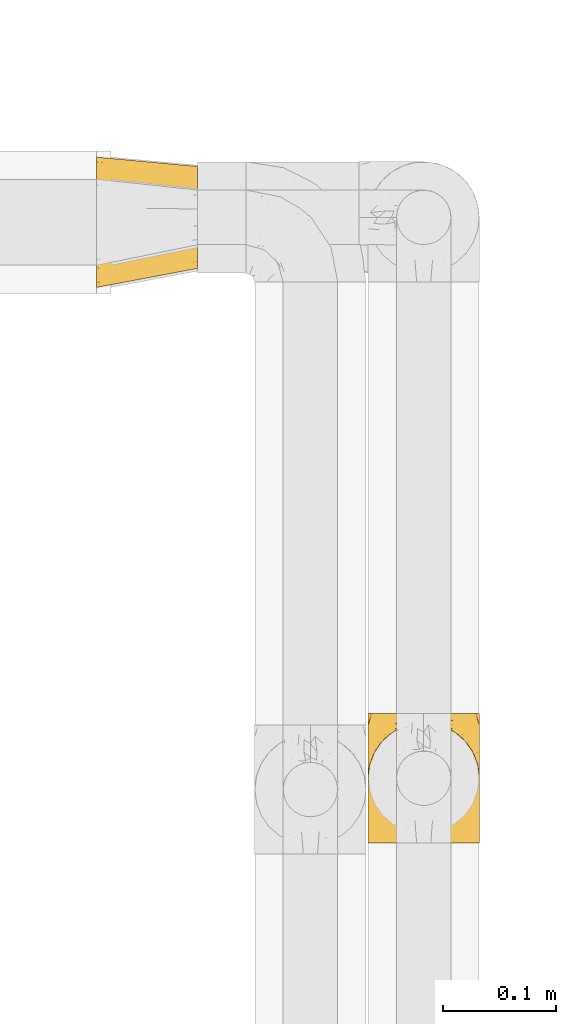
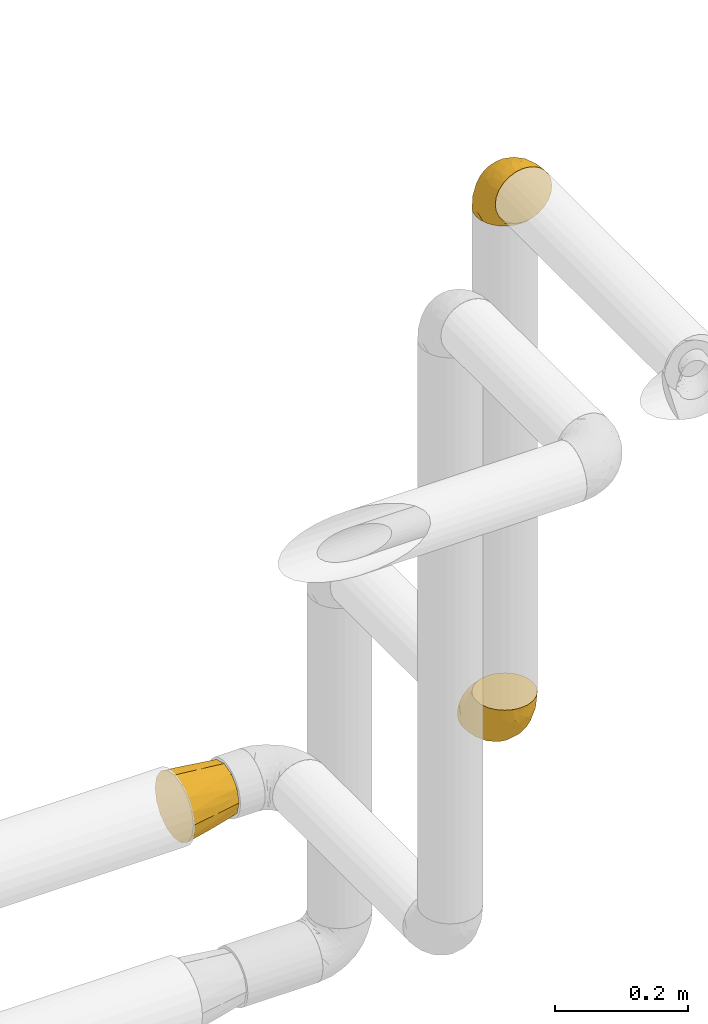
# One storey, part 416 of 827: 3 coverings.
"""IFC2X3 building model written with IfcOpenShell, lengths in millimetres."""

import ifcopenshell
import ifcopenshell.guid

model = None  # the IFC model being written
_history = None  # IfcOwnerHistory: only IFC2X3 demands one
_inside = {}  # id of a spatial element -> (the spatial element, [elements in it])
_under = {}  # id of a project, library or spatial element -> (it, [spatial elements below it])
_declared = {}  # id of a project -> (the project, [libraries it declares])
_typed = {}  # id of a type object -> (the type object, [elements of that type])
_made_of = {}  # id of a material, layer set ... -> (it, [elements and type objects made of it])


def new_model(schema):
    """Start an empty IFC model of exactly this schema.

    Asked for "IFC4X3", IfcOpenShell would pick the latest addendum, in which some entities
    have other attributes; the version numbers below select the first issue.
    IFC2X3 requires an IfcOwnerHistory on every rooted entity: one is made here for all.
    """
    global model, _history
    if schema == "IFC4X3":
        model = ifcopenshell.file(schema_version=(4, 3, 0, 0))
    else:
        model = ifcopenshell.file(schema=schema)
    _inside.clear()
    _under.clear()
    _declared.clear()
    _typed.clear()
    _made_of.clear()
    _history = None
    if model.schema == "IFC2X3":
        org = make("IfcOrganization", Name="unknown")
        user = make(
            "IfcPersonAndOrganization",
            ThePerson=make("IfcPerson", FamilyName="unknown"),
            TheOrganization=org,
        )
        app = make(
            "IfcApplication",
            ApplicationDeveloper=org,
            Version="unknown",
            ApplicationFullName="unknown",
            ApplicationIdentifier="unknown",
        )
        _history = make(
            "IfcOwnerHistory",
            OwningUser=user,
            OwningApplication=app,
            ChangeAction="ADDED",
            CreationDate=0,
        )
    return model


def make(cls, **values):
    """One entity of the class cls with the attributes given. An attribute that is None is left unset."""
    return model.create_entity(
        cls, **{name: value for name, value in values.items() if value is not None}
    )


def entity(cls, *values):
    """Any entity or typed value of the class cls, its attributes in the order of the schema. None: left unset."""
    e = model.create_entity(cls)
    for i, value in enumerate(values):
        if value is not None:
            e[i] = value
    return e


def rooted(cls, **values):
    """An entity with a GlobalId (a new one), such as an element, a storey or a relation."""
    return make(cls, GlobalId=ifcopenshell.guid.new(), OwnerHistory=_history, **values)


def si_unit(unit_type, name, prefix=None):
    """IfcSIUnit, for example si_unit("LENGTHUNIT", "METRE", prefix="MILLI")."""
    return make("IfcSIUnit", UnitType=unit_type, Prefix=prefix, Name=name)


def converted_unit(unit_type, name, factor, base, dimensions=None, offset=None):
    """IfcConversionBasedUnit, such as the inch: factor (a typed value) times the base unit."""
    return make(
        "IfcConversionBasedUnit"
        if offset is None
        else "IfcConversionBasedUnitWithOffset",
        ConversionOffset=offset,
        Dimensions=None
        if dimensions is None
        else entity("IfcDimensionalExponents", *dimensions),
        UnitType=unit_type,
        Name=name,
        ConversionFactor=make(
            "IfcMeasureWithUnit", ValueComponent=factor, UnitComponent=base
        ),
    )


def derived_unit(unit_type, elements):
    """IfcDerivedUnit: a product of units, each with its exponent."""
    return make(
        "IfcDerivedUnit",
        Elements=[
            make("IfcDerivedUnitElement", Unit=unit, Exponent=power)
            for unit, power in elements
        ],
        UnitType=unit_type,
    )


def assignment(units):
    """IfcUnitAssignment: the units of a project."""
    return None if units is None else make("IfcUnitAssignment", Units=units)


def point(xyz):
    """IfcCartesianPoint."""
    return None if xyz is None else make("IfcCartesianPoint", Coordinates=xyz)


def direction(xyz):
    """IfcDirection."""
    return None if xyz is None else make("IfcDirection", DirectionRatios=xyz)


def frame(location, z_axis=None, x_axis=None):
    """IfcAxis2Placement3D, a coordinate frame: its origin and axes. An axis left out is left unset."""
    return make(
        "IfcAxis2Placement3D",
        Location=point(location),
        Axis=direction(z_axis),
        RefDirection=direction(x_axis),
    )


def origin():
    """The frame at (0, 0, 0) with its axes left unset."""
    return frame((0.0, 0.0, 0.0))


def place(relative_to, where):
    """IfcLocalPlacement: puts the frame where relative to a parent placement (None: the world)."""
    return make(
        "IfcLocalPlacement", PlacementRelTo=relative_to, RelativePlacement=where
    )


def context(
    kind, dimensions, precision=None, world=None, true_north=None, identifier=None
):
    """IfcGeometricRepresentationContext, for example the 3D "Model" context."""
    return make(
        "IfcGeometricRepresentationContext",
        ContextIdentifier=identifier,
        ContextType=kind,
        CoordinateSpaceDimension=dimensions,
        Precision=precision,
        WorldCoordinateSystem=world,
        TrueNorth=true_north,
    )


def subcontext(parent, identifier, kind, view, scale=None):
    """IfcGeometricRepresentationSubContext, for example "Body" below "Model"."""
    return make(
        "IfcGeometricRepresentationSubContext",
        ContextIdentifier=identifier,
        ContextType=kind,
        ParentContext=parent,
        TargetScale=scale,
        TargetView=view,
    )


def project(units=None, contexts=None):
    """IfcProject with its units and contexts."""
    return rooted(
        "IfcProject",
        Name="project",
        RepresentationContexts=contexts,
        UnitsInContext=assignment(units),
    )


def spatial(cls, under=None, at=None, **own):
    """A site, building, storey or space (cls), placed at a placement, below another one or the project."""
    s = rooted(cls, ObjectPlacement=at, **own)
    if under is not None:
        _under.setdefault(under.id(), (under, []))[1].append(s)
    return s


def faces_of(points, faces, orient=None, outer=None):
    """IfcFace entities. A face is a list of loops; a loop is a list of indices into points, from 0.

    orient and outer hold one flag for each loop. By default every Orientation is true, the
    first loop of a face is its IfcFaceOuterBound and the others are IfcFaceBound.
    """
    made = []
    for i, loops in enumerate(faces):
        bounds = []
        for j, loop in enumerate(loops):
            is_outer = j == 0 if outer is None else outer[i][j]
            bounds.append(
                make(
                    "IfcFaceOuterBound" if is_outer else "IfcFaceBound",
                    Bound=make("IfcPolyLoop", Polygon=[points[k] for k in loop]),
                    Orientation=True if orient is None else orient[i][j],
                )
            )
        made.append(make("IfcFace", Bounds=bounds))
    return made


def faceted_brep(points, faces, orient=None, outer=None, voids=None):
    """IfcFacetedBrep: a solid bounded by flat faces; with voids (closed shells), ...WithVoids."""
    shared = [point(p) for p in points]
    hull = make("IfcClosedShell", CfsFaces=faces_of(shared, faces, orient, outer))
    if voids is None:
        return make("IfcFacetedBrep", Outer=hull)
    return make(
        "IfcFacetedBrepWithVoids",
        Outer=hull,
        Voids=[
            make(cls, CfsFaces=faces_of(shared, fs, o, b)) for cls, fs, o, b in voids
        ],
    )


def shape(context_of_items, identifier, shape_type, items):
    """IfcShapeRepresentation: the items that make up one representation, for example the "Body"."""
    return make(
        "IfcShapeRepresentation",
        ContextOfItems=context_of_items,
        RepresentationIdentifier=identifier,
        RepresentationType=shape_type,
        Items=items,
    )


def made_of(thing, what):
    """Note that an element or type object is made of a material, layer set ...; save() writes the relation."""
    if what is not None:
        _made_of.setdefault(what.id(), (what, []))[1].append(thing)
    return thing


def element(
    cls,
    number,
    at=None,
    inside=None,
    cuts=None,
    type_object=None,
    material=None,
    context=None,
    identifier="Body",
    shape_type=None,
    held_by="IfcProductDefinitionShape",
    body=None,
    shapes=None,
    **own,
):
    """One element of the class cls, such as IfcWall. Its Tag is "e" and its number.

    at: its placement. inside: the storey or other place that contains it. cuts: it is an
    opening in that element (IfcRelVoidsElement). A single representation is given by context,
    identifier, shape_type and body (its items); several are given by shapes. held_by: the class
    of the entity that holds the representations. save() writes the other relations.
    """
    e = rooted(cls, Tag="e%d" % number, ObjectPlacement=at, **own)
    if body is not None:
        shapes = [shape(context, identifier, shape_type, body)]
    if shapes is not None:
        e.Representation = make(held_by, Representations=shapes)
    if inside is not None:
        _inside.setdefault(inside.id(), (inside, []))[1].append(e)
    if cuts is not None:
        rooted(
            "IfcRelVoidsElement", RelatingBuildingElement=cuts, RelatedOpeningElement=e
        )
    if type_object is not None:
        _typed.setdefault(type_object.id(), (type_object, []))[1].append(e)
    return made_of(e, material)


def aggregate(whole, parts):
    """IfcRelAggregates: a whole, such as a stair, and the parts it consists of."""
    return rooted("IfcRelAggregates", RelatingObject=whole, RelatedObjects=parts)


def save(model, path):
    """Write the relations noted so far, then the file.

    IfcRelAggregates (storeys below a building ...), IfcRelContainedInSpatialStructure (elements
    in a storey), IfcRelDefinesByType, IfcRelAssociatesMaterial and IfcRelDeclares: one each for
    every whole, place, type object, material and project.
    """
    for whole, parts in _under.values():
        aggregate(whole, parts)
    for where, things in _inside.values():
        rooted(
            "IfcRelContainedInSpatialStructure",
            RelatedElements=things,
            RelatingStructure=where,
        )
    for kind, things in _typed.values():
        rooted("IfcRelDefinesByType", RelatedObjects=things, RelatingType=kind)
    for what, things in _made_of.values():
        rooted("IfcRelAssociatesMaterial", RelatedObjects=things, RelatingMaterial=what)
    for by, libraries in _declared.values():
        rooted("IfcRelDeclares", RelatingContext=by, RelatedDefinitions=libraries)
    model.write(path)


model = new_model("IFC2X3")

# Units and contexts
model_context = context("Model", 3, precision=0.01, world=origin(), true_north=direction((6.12303176911189e-17, 1.0)))
body_context = subcontext(model_context, "Body", "Model", "MODEL_VIEW")
ifc_project = project(units=[si_unit("LENGTHUNIT", "METRE", prefix="MILLI"), si_unit("AREAUNIT", "SQUARE_METRE"), si_unit("VOLUMEUNIT", "CUBIC_METRE"), converted_unit("PLANEANGLEUNIT", "DEGREE", entity("IfcRatioMeasure", 0.0174532925199433), si_unit("PLANEANGLEUNIT", "RADIAN"), dimensions=[0, 0, 0, 0, 0, 0, 0]), si_unit("MASSUNIT", "GRAM", prefix="KILO"), derived_unit("MASSDENSITYUNIT", [(si_unit("MASSUNIT", "GRAM", prefix="KILO"), 1), (si_unit("LENGTHUNIT", "METRE"), -3)]), derived_unit("MOMENTOFINERTIAUNIT", [(si_unit("LENGTHUNIT", "METRE"), 4)]), si_unit("TIMEUNIT", "SECOND"), si_unit("FREQUENCYUNIT", "HERTZ"), si_unit("THERMODYNAMICTEMPERATUREUNIT", "DEGREE_CELSIUS"), derived_unit("THERMALTRANSMITTANCEUNIT", [(si_unit("MASSUNIT", "GRAM", prefix="KILO"), 1), (si_unit("THERMODYNAMICTEMPERATUREUNIT", "KELVIN"), -1), (si_unit("TIMEUNIT", "SECOND"), -3)]), derived_unit("VOLUMETRICFLOWRATEUNIT", [(si_unit("LENGTHUNIT", "METRE"), 3), (si_unit("TIMEUNIT", "SECOND"), -1)]), derived_unit("MASSFLOWRATEUNIT", [(si_unit("MASSUNIT", "GRAM", prefix="KILO"), 1), (si_unit("TIMEUNIT", "SECOND"), -1)]), derived_unit("ROTATIONALFREQUENCYUNIT", [(si_unit("TIMEUNIT", "SECOND"), -1)]), si_unit("ELECTRICCURRENTUNIT", "AMPERE"), si_unit("ELECTRICVOLTAGEUNIT", "VOLT"), si_unit("POWERUNIT", "WATT"), si_unit("FORCEUNIT", "NEWTON", prefix="KILO"), si_unit("ILLUMINANCEUNIT", "LUX"), si_unit("LUMINOUSFLUXUNIT", "LUMEN"), si_unit("LUMINOUSINTENSITYUNIT", "CANDELA"), derived_unit("USERDEFINED", [(si_unit("MASSUNIT", "GRAM", prefix="KILO"), -1), (si_unit("LENGTHUNIT", "METRE"), -2), (si_unit("TIMEUNIT", "SECOND"), 3), (si_unit("LUMINOUSFLUXUNIT", "LUMEN"), 1)]), derived_unit("LINEARVELOCITYUNIT", [(si_unit("LENGTHUNIT", "METRE"), 1), (si_unit("TIMEUNIT", "SECOND"), -1)]), si_unit("PRESSUREUNIT", "PASCAL"), derived_unit("USERDEFINED", [(si_unit("LENGTHUNIT", "METRE"), -2), (si_unit("MASSUNIT", "GRAM", prefix="KILO"), 1), (si_unit("TIMEUNIT", "SECOND"), -2)]), derived_unit("LINEARFORCEUNIT", [(si_unit("MASSUNIT", "GRAM", prefix="KILO"), 1), (si_unit("LENGTHUNIT", "METRE"), 1), (si_unit("TIMEUNIT", "SECOND"), -2), (si_unit("LENGTHUNIT", "METRE"), -1)]), derived_unit("PLANARFORCEUNIT", [(si_unit("MASSUNIT", "GRAM", prefix="KILO"), 1), (si_unit("LENGTHUNIT", "METRE"), 1), (si_unit("TIMEUNIT", "SECOND"), -2), (si_unit("LENGTHUNIT", "METRE"), -2)])], contexts=[model_context])

# Site, building, storey
site_placement = place(None, origin())
site = spatial("IfcSite", under=ifc_project, at=site_placement, CompositionType="ELEMENT")
building_placement = place(site_placement, origin())
building = spatial("IfcBuilding", under=site, at=building_placement, CompositionType="ELEMENT")
storey_placement = place(building_placement, frame((0.0, 0.0, 28200.0)))
storey = spatial("IfcBuildingStorey", under=building, at=storey_placement, Name="08", CompositionType="ELEMENT", Elevation=28200.0)

# Coverings
covering_1_placement = place(storey_placement, frame((50083.3, 19082.13, 1590.9)))
element("IfcCovering", 1, at=covering_1_placement, inside=storey, Name=":ADSK_", ObjectType=":ADSK_", PredefinedType="INSULATION", context=body_context, shape_type="Brep", body=[
    faceted_brep([(0.0, 99.75, 99.75), (0.0, 105.99, 90.43), (0.0, 112.22, 81.1), (0.0, 114.41, 70.1), (0.0, 116.6, 59.1), (0.0, 114.55, 48.79), (0.0, 112.22, 37.09), (0.0, 105.99, 27.76), (0.0, 99.75, 18.44), (0.0, 90.43, 12.2), (0.0, 81.1, 5.97), (0.0, 70.1, 3.78), (0.0, 59.1, 1.6), (0.0, 48.84, 3.63), (0.0, 37.09, 5.97), (0.0, 27.76, 12.2), (0.0, 18.44, 18.44), (0.0, 12.2, 27.76), (0.0, 5.97, 37.09), (0.0, 3.78, 48.09), (0.0, 1.6, 59.1), (0.0, 3.63, 69.35), (0.0, 5.97, 81.1), (0.0, 12.2, 90.43), (0.0, 18.44, 99.75), (0.0, 27.76, 105.99), (0.0, 37.09, 112.22), (0.0, 48.09, 114.41), (0.0, 59.1, 116.6), (0.0, 69.4, 114.55), (0.0, 81.1, 112.22), (0.0, 90.43, 105.99), (89.0, 32.67, 89.83), (89.0, 24.43, 81.6), (89.0, 21.42, 70.35), (89.0, 18.4, 59.1), (89.0, 21.42, 47.85), (89.0, 24.43, 36.6), (89.0, 32.67, 28.36), (89.0, 40.9, 20.12), (89.0, 52.15, 17.11), (89.0, 63.4, 14.1), (89.0, 74.65, 17.11), (89.0, 85.9, 20.12), (89.0, 94.14, 28.36), (89.0, 102.37, 36.6), (89.0, 105.39, 47.85), (89.0, 108.4, 59.1), (89.0, 105.39, 70.35), (89.0, 102.37, 81.6), (89.0, 94.14, 89.83), (89.0, 85.9, 98.07), (89.0, 74.65, 101.08), (89.0, 63.4, 104.1), (89.0, 52.15, 101.08), (89.0, 40.9, 98.07), (46.81, 112.29, 59.1), (41.48, 110.64, 44.4), (41.49, 106.52, 34.46), (42.19, 112.71, 59.1), (44.5, 92.45, 18.44), (43.62, 74.0, 9.34), (44.5, 100.21, 25.8), (45.16, 83.52, 13.02), (42.19, 61.14, 7.52), (47.01, 61.37, 8.2), (41.45, 46.43, 9.54), (41.53, 36.49, 13.67), (44.5, 20.59, 27.9), (43.62, 11.45, 46.3), (44.5, 27.95, 20.14), (45.16, 15.21, 36.86), (41.99, 9.53, 59.1), (47.01, 10.47, 59.1), (41.45, 11.55, 73.77), (41.53, 15.68, 83.71), (44.5, 30.05, 99.75), (43.62, 48.41, 108.85), (44.5, 22.29, 92.39), (45.16, 39.04, 105.17), (41.99, 61.13, 110.7), (46.81, 61.36, 110.02), (41.48, 75.79, 108.64), (41.49, 85.74, 104.52), (44.5, 101.91, 90.29), (43.62, 110.96, 71.89), (44.5, 94.55, 98.05), (45.16, 107.35, 81.33)], [[[0, 1, 2, 3, 4, 5, 6, 7, 8, 9, 10, 11, 12, 13, 14, 15, 16, 17, 18, 19, 20, 21, 22, 23, 24, 25, 26, 27, 28, 29, 30, 31]], [[32, 33, 34, 35, 36, 37, 38, 39, 40, 41, 42, 43, 44, 45, 46, 47, 48, 49, 50, 51, 52, 53, 54, 55]], [[46, 56, 47]], [[57, 46, 58]], [[5, 4, 59, 56]], [[56, 57, 5]], [[58, 6, 57]], [[60, 44, 43]], [[61, 42, 41]], [[62, 7, 58]], [[8, 62, 60]], [[9, 63, 10]], [[58, 46, 45]], [[6, 5, 57]], [[44, 60, 62]], [[44, 62, 45]], [[63, 60, 43]], [[57, 56, 46]], [[7, 6, 58]], [[63, 9, 60]], [[7, 62, 8]], [[45, 62, 58]], [[61, 63, 42]], [[64, 11, 61]], [[61, 41, 65, 64]], [[63, 43, 42]], [[63, 61, 10]], [[64, 12, 11]], [[9, 8, 60]], [[10, 61, 11]], [[40, 65, 41]], [[66, 40, 67]], [[13, 12, 64, 65]], [[65, 66, 13]], [[67, 14, 66]], [[68, 38, 37]], [[69, 36, 35]], [[70, 15, 67]], [[16, 70, 68]], [[17, 71, 18]], [[67, 40, 39]], [[14, 13, 66]], [[38, 68, 70]], [[38, 70, 39]], [[71, 68, 37]], [[66, 65, 40]], [[15, 14, 67]], [[71, 17, 68]], [[15, 70, 16]], [[39, 70, 67]], [[69, 71, 36]], [[72, 19, 69]], [[69, 35, 73, 72]], [[71, 37, 36]], [[71, 69, 18]], [[72, 20, 19]], [[17, 16, 68]], [[18, 69, 19]], [[34, 73, 35]], [[74, 34, 75]], [[21, 20, 72, 73]], [[73, 74, 21]], [[75, 22, 74]], [[76, 32, 55]], [[77, 54, 53]], [[78, 23, 75]], [[24, 78, 76]], [[25, 79, 26]], [[75, 34, 33]], [[22, 21, 74]], [[32, 76, 78]], [[32, 78, 33]], [[79, 76, 55]], [[74, 73, 34]], [[23, 22, 75]], [[79, 25, 76]], [[23, 78, 24]], [[33, 78, 75]], [[77, 79, 54]], [[80, 27, 77]], [[77, 53, 81, 80]], [[79, 55, 54]], [[79, 77, 26]], [[80, 28, 27]], [[25, 24, 76]], [[26, 77, 27]], [[52, 81, 53]], [[82, 52, 83]], [[29, 28, 80, 81]], [[81, 82, 29]], [[83, 30, 82]], [[84, 50, 49]], [[85, 48, 47]], [[86, 31, 83]], [[0, 86, 84]], [[1, 87, 2]], [[83, 52, 51]], [[30, 29, 82]], [[50, 84, 86]], [[50, 86, 51]], [[87, 84, 49]], [[82, 81, 52]], [[31, 30, 83]], [[87, 1, 84]], [[31, 86, 0]], [[51, 86, 83]], [[85, 87, 48]], [[59, 3, 85]], [[85, 47, 56, 59]], [[87, 49, 48]], [[87, 85, 2]], [[59, 4, 3]], [[1, 0, 84]], [[2, 85, 3]]]),
])
covering_2_placement = place(storey_placement, frame((50321.29, 18591.93, 2941.4)))
element("IfcCovering", 2, at=covering_2_placement, inside=storey, Name=":ADSK_", ObjectType=":ADSK_", PredefinedType="INSULATION", context=body_context, shape_type="Brep", body=[
    faceted_brep([(1.6, 58.6, 1.6), (2.83, 69.54, 1.6), (6.47, 79.93, 1.6), (12.32, 89.25, 1.6), (20.11, 97.03, 1.6), (29.43, 102.88, 1.6), (39.81, 106.51, 1.6), (50.75, 107.75, 1.6), (61.69, 106.51, 1.6), (72.08, 102.87, 1.6), (81.4, 97.02, 1.6), (89.18, 89.23, 1.6), (95.03, 79.91, 1.6), (98.66, 69.53, 1.6), (99.9, 58.6, 1.6), (99.25, 52.89, 1.6), (98.66, 47.65, 1.6), (96.84, 42.46, 1.6), (95.02, 37.26, 1.6), (89.17, 27.94, 1.6), (81.38, 20.16, 1.6), (72.06, 14.31, 1.6), (61.68, 10.68, 1.6), (50.75, 9.45, 1.6), (39.8, 10.68, 1.6), (29.41, 14.32, 1.6), (20.09, 20.17, 1.6), (12.31, 27.96, 1.6), (6.46, 37.28, 1.6), (4.64, 42.47, 1.6), (2.83, 47.66, 1.6), (2.24, 52.89, 1.6), (1.92, 55.75, 1.6), (63.47, 1.6, 11.12), (75.32, 1.6, 16.03), (80.41, 1.6, 19.94), (85.5, 1.6, 23.84), (89.4, 1.6, 28.93), (93.31, 1.6, 34.02), (95.77, 1.6, 39.95), (98.22, 1.6, 45.87), (99.14, 1.6, 52.86), (99.52, 1.6, 55.73), (99.9, 1.6, 58.6), (98.22, 1.6, 71.32), (93.31, 1.6, 83.17), (85.5, 1.6, 93.35), (75.32, 1.6, 101.16), (63.47, 1.6, 106.07), (50.75, 1.6, 107.75), (38.02, 1.6, 106.07), (26.17, 1.6, 101.16), (15.99, 1.6, 93.35), (8.18, 1.6, 83.17), (3.27, 1.6, 71.32), (1.6, 1.6, 58.6), (2.35, 1.6, 52.86), (3.27, 1.6, 45.87), (5.73, 1.6, 39.95), (8.18, 1.6, 34.02), (12.09, 1.6, 28.93), (15.99, 1.6, 23.84), (21.08, 1.6, 19.94), (26.17, 1.6, 16.03), (38.02, 1.6, 11.12), (50.75, 1.6, 9.45), (42.18, 69.96, 81.82), (28.42, 59.59, 84.02), (37.78, 51.96, 93.05), (50.75, 34.4, 102.55), (42.85, 23.37, 104.83), (50.75, 13.68, 105.83), (24.75, 41.52, 91.87), (33.81, 26.26, 101.74), (22.57, 20.18, 97.07), (7.18, 72.33, 38.45), (2.73, 65.88, 22.17), (3.09, 57.55, 42.04), (6.92, 23.76, 77.69), (11.58, 46.5, 75.76), (5.17, 46.57, 62.11), (2.71, 21.17, 66.08), (1.6, 23.41, 54.26), (1.6, 17.92, 55.35), (1.6, 12.43, 56.44), (1.6, 9.72, 56.98), (1.6, 7.01, 57.52), (14.18, 26.77, 87.84), (5.88, 76.59, 19.41), (41.06, 95.55, 48.89), (36.25, 102.57, 26.34), (28.62, 92.89, 44.55), (1.6, 54.26, 23.41), (1.6, 51.17, 28.03), (1.6, 48.08, 32.65), (1.6, 44.99, 37.28), (1.6, 41.9, 41.9), (10.85, 85.16, 20.6), (38.35, 85.97, 63.36), (9.6, 59.58, 62.21), (26.24, 99.5, 19.94), (50.75, 105.83, 13.68), (19.31, 53.59, 80.85), (16.41, 67.0, 66.53), (24.56, 71.56, 71.06), (50.75, 87.47, 63.99), (50.75, 75.73, 75.73), (18.47, 92.24, 26.77), (1.6, 58.06, 4.31), (1.6, 57.52, 7.01), (1.6, 56.44, 12.43), (1.6, 55.35, 17.92), (14.36, 81.33, 43.43), (20.64, 80.35, 56.23), (2.32, 39.44, 54.97), (50.75, 102.55, 34.4), (1.6, 37.28, 44.99), (1.6, 32.65, 48.08), (1.6, 28.03, 51.17), (50.75, 63.99, 87.47), (33.88, 74.55, 74.55), (29.24, 83.62, 60.86), (50.75, 95.01, 49.19), (50.75, 49.19, 95.01), (2.8, 46.96, 10.27), (2.48, 8.77, 48.79), (2.7, 18.28, 45.16), (3.2, 11.68, 44.99), (32.98, 11.79, 6.17), (24.67, 15.69, 7.65), (2.95, 42.49, 21.59), (2.19, 47.41, 19.96), (17.92, 7.94, 21.0), (12.02, 9.27, 27.2), (25.73, 7.98, 14.83), (16.63, 13.4, 19.7), (25.6, 13.04, 10.93), (36.72, 7.36, 9.63), (10.66, 23.46, 19.97), (6.87, 30.46, 21.13), (11.12, 26.54, 14.14), (10.31, 6.76, 30.2), (12.84, 26.46, 8.12), (17.38, 20.77, 9.93), (9.74, 20.68, 24.62), (4.63, 40.26, 11.87), (50.75, 7.15, 7.15), (42.52, 9.28, 5.32), (3.12, 38.78, 26.68), (17.58, 18.27, 13.92), (3.97, 31.78, 30.67), (5.94, 12.75, 36.65), (2.73, 22.96, 42.89), (6.23, 17.55, 34.04), (3.45, 27.63, 36.6), (10.84, 15.23, 26.41), (7.98, 33.25, 10.07), (7.33, 32.43, 15.83), (2.39, 27.9, 41.99), (75.76, 7.97, 14.83), (90.65, 15.22, 26.4), (83.57, 7.93, 21.01), (84.85, 13.38, 19.71), (71.05, 13.12, 5.72), (98.54, 42.49, 21.6), (99.3, 47.4, 19.96), (99.9, 51.17, 28.03), (96.86, 40.24, 11.87), (84.1, 20.76, 9.93), (99.9, 12.43, 56.44), (99.9, 7.01, 57.52), (99.9, 4.31, 58.06), (88.63, 26.44, 8.13), (90.36, 26.52, 14.15), (98.29, 11.68, 44.99), (95.55, 12.75, 36.65), (89.47, 9.27, 27.21), (95.26, 17.55, 34.04), (91.18, 6.76, 30.2), (93.49, 33.21, 10.06), (94.15, 32.41, 15.83), (99.01, 8.77, 48.79), (98.76, 22.96, 42.89), (98.85, 18.48, 45.38), (99.9, 56.44, 12.43), (98.69, 46.95, 10.28), (64.78, 7.36, 9.64), (99.9, 17.92, 55.35), (99.9, 23.41, 54.26), (62.91, 9.85, 6.05), (99.9, 57.52, 7.01), (99.9, 56.98, 9.72), (99.9, 48.08, 32.65), (98.37, 38.78, 26.68), (83.9, 18.25, 13.92), (99.9, 44.99, 37.28), (97.51, 31.74, 30.66), (94.62, 30.45, 21.14), (98.04, 27.63, 36.59), (91.73, 20.65, 24.6), (99.9, 55.35, 17.92), (99.9, 54.26, 23.41), (75.87, 13.03, 10.93), (90.83, 23.44, 19.97), (99.1, 27.9, 41.99), (99.9, 32.65, 48.08), (99.9, 28.03, 51.17), (99.9, 37.28, 44.99), (99.9, 41.9, 41.9), (99.09, 39.74, 55.26), (58.64, 23.37, 104.83), (87.31, 26.77, 87.84), (89.93, 46.18, 75.91), (82.22, 53.54, 80.84), (76.74, 41.53, 91.87), (73.12, 59.61, 83.98), (95.54, 76.79, 19.16), (98.7, 66.11, 22.37), (98.79, 21.17, 66.08), (63.71, 51.96, 93.05), (67.68, 26.26, 101.74), (78.92, 20.18, 97.07), (94.57, 23.76, 77.69), (72.88, 92.88, 44.55), (65.25, 102.57, 26.34), (60.44, 95.54, 48.9), (76.94, 71.63, 70.99), (67.61, 74.55, 74.55), (94.38, 72.51, 37.8), (59.31, 69.96, 81.82), (83.03, 92.23, 26.77), (90.66, 85.15, 20.6), (80.8, 80.45, 56.15), (72.22, 83.65, 60.85), (98.39, 57.57, 42.06), (92.31, 63.68, 57.03), (63.11, 85.95, 63.4), (75.27, 99.49, 19.94), (87.15, 81.23, 43.59), (96.03, 47.07, 62.61), (85.1, 66.99, 66.52)], [[[0, 1, 2, 3, 4, 5, 6, 7, 8, 9, 10, 11, 12, 13, 14, 15, 16, 17, 18, 19, 20, 21, 22, 23, 24, 25, 26, 27, 28, 29, 30, 31, 32]], [[33, 34, 35, 36, 37, 38, 39, 40, 41, 42, 43, 44, 45, 46, 47, 48, 49, 50, 51, 52, 53, 54, 55, 56, 57, 58, 59, 60, 61, 62, 63, 64, 65]], [[66, 67, 68]], [[69, 70, 71]], [[68, 72, 73]], [[73, 72, 74]], [[75, 76, 77]], [[78, 79, 80]], [[51, 50, 73]], [[81, 82, 83, 84, 85, 86, 55]], [[52, 87, 53]], [[74, 52, 51]], [[2, 1, 88]], [[89, 90, 91]], [[77, 92, 93, 94, 95, 96]], [[55, 54, 81]], [[78, 53, 87]], [[5, 90, 6]], [[88, 76, 75]], [[97, 3, 2]], [[89, 91, 98]], [[99, 80, 79]], [[90, 5, 100]], [[74, 87, 52]], [[100, 5, 4]], [[90, 101, 6]], [[79, 102, 103]], [[102, 67, 104]], [[105, 98, 106]], [[107, 4, 3]], [[76, 0, 108, 109, 110, 111, 92]], [[107, 112, 113]], [[114, 77, 96]], [[89, 115, 90]], [[114, 96, 116, 117, 118, 82]], [[75, 97, 88]], [[119, 66, 68]], [[50, 71, 70]], [[100, 91, 90]], [[99, 77, 80]], [[102, 104, 103]], [[97, 107, 3]], [[80, 81, 78]], [[107, 97, 112]], [[68, 73, 70]], [[66, 98, 120]], [[78, 81, 54]], [[114, 81, 80]], [[53, 78, 54]], [[78, 87, 79]], [[102, 87, 72]], [[79, 103, 99]], [[4, 107, 100]], [[91, 100, 107]], [[88, 97, 2]], [[112, 97, 75]], [[99, 112, 75]], [[103, 104, 113]], [[91, 121, 98]], [[89, 105, 122, 115]], [[101, 90, 115]], [[101, 7, 6]], [[88, 1, 76]], [[0, 76, 1]], [[92, 77, 76]], [[73, 74, 51]], [[87, 74, 72]], [[81, 114, 82]], [[77, 114, 80]], [[87, 102, 79]], [[67, 102, 72]], [[68, 67, 72]], [[67, 120, 104]], [[120, 121, 104]], [[104, 121, 113]], [[121, 120, 98]], [[91, 107, 113]], [[91, 113, 121]], [[103, 113, 112]], [[106, 98, 66]], [[105, 89, 98]], [[106, 66, 119]], [[67, 66, 120]], [[68, 69, 123, 119]], [[50, 49, 71]], [[50, 70, 73]], [[112, 99, 103]], [[77, 99, 75]], [[69, 68, 70]], [[29, 124, 110]], [[84, 83, 125]], [[126, 82, 118]], [[59, 58, 127]], [[25, 128, 129]], [[130, 93, 131]], [[132, 62, 133]], [[134, 135, 136]], [[137, 65, 64]], [[64, 134, 137]], [[138, 139, 140]], [[111, 110, 124, 92]], [[134, 136, 137]], [[134, 64, 63]], [[141, 61, 60]], [[125, 58, 57]], [[142, 143, 140]], [[142, 26, 143]], [[127, 83, 82]], [[28, 124, 29]], [[108, 0, 32, 31, 30, 110, 109]], [[30, 29, 110]], [[135, 144, 138]], [[28, 145, 124]], [[57, 56, 55, 86, 85, 84]], [[146, 147, 23]], [[24, 23, 147]], [[25, 143, 26]], [[95, 94, 148]], [[24, 128, 25]], [[149, 138, 143]], [[124, 145, 131]], [[127, 58, 125]], [[150, 148, 139]], [[127, 126, 151]], [[151, 59, 127]], [[152, 151, 126]], [[153, 154, 155]], [[153, 133, 141]], [[145, 28, 27]], [[142, 156, 27]], [[157, 148, 130]], [[61, 133, 62]], [[134, 132, 135]], [[147, 128, 24]], [[65, 137, 146]], [[146, 137, 147]], [[128, 137, 136]], [[137, 128, 147]], [[128, 136, 129]], [[149, 129, 136]], [[25, 129, 143]], [[158, 152, 117]], [[152, 118, 117]], [[153, 151, 152]], [[158, 116, 154]], [[144, 150, 138]], [[153, 152, 158]], [[133, 153, 155]], [[133, 155, 132]], [[60, 151, 141]], [[135, 132, 155]], [[134, 63, 132]], [[144, 135, 155]], [[135, 138, 149]], [[155, 154, 144]], [[150, 154, 96]], [[154, 150, 144]], [[148, 94, 130]], [[82, 126, 127]], [[118, 152, 126]], [[150, 96, 95]], [[139, 148, 157]], [[150, 95, 148]], [[93, 92, 131]], [[130, 145, 156]], [[130, 94, 93]], [[84, 125, 57]], [[127, 125, 83]], [[140, 139, 157]], [[150, 139, 138]], [[140, 157, 142]], [[138, 140, 143]], [[156, 142, 157]], [[27, 26, 142]], [[130, 156, 157]], [[145, 27, 156]], [[132, 63, 62]], [[124, 131, 92]], [[130, 131, 145]], [[129, 149, 143]], [[135, 149, 136]], [[141, 133, 61]], [[60, 59, 151]], [[141, 151, 153]], [[116, 96, 154]], [[153, 158, 154]], [[158, 117, 116]], [[34, 33, 159]], [[160, 161, 162]], [[22, 21, 163]], [[164, 165, 166]], [[19, 18, 167]], [[168, 21, 20]], [[42, 41, 40, 169, 170, 171, 43]], [[172, 173, 168]], [[174, 38, 175]], [[176, 177, 178]], [[179, 164, 180]], [[40, 181, 169]], [[182, 183, 175]], [[17, 184, 185]], [[65, 146, 186]], [[187, 174, 188]], [[23, 22, 189]], [[174, 39, 38]], [[15, 14, 190, 191, 184, 16]], [[181, 40, 39]], [[192, 193, 164]], [[194, 163, 168]], [[33, 186, 159]], [[180, 173, 172]], [[195, 196, 193]], [[18, 185, 167]], [[173, 180, 197]], [[198, 199, 196]], [[200, 201, 185, 184]], [[184, 17, 16]], [[18, 17, 185]], [[202, 159, 186]], [[194, 168, 203]], [[189, 163, 202]], [[204, 205, 182]], [[187, 181, 174]], [[160, 177, 176]], [[206, 183, 182]], [[206, 182, 205]], [[201, 165, 185]], [[165, 164, 167]], [[172, 179, 180]], [[202, 194, 162]], [[176, 161, 160]], [[65, 186, 33]], [[163, 189, 22]], [[175, 177, 182]], [[174, 183, 188]], [[177, 198, 204]], [[199, 160, 162]], [[198, 207, 204]], [[175, 38, 37]], [[198, 177, 160]], [[178, 177, 175]], [[176, 35, 161]], [[34, 159, 161]], [[162, 161, 159]], [[202, 162, 159]], [[199, 162, 203]], [[196, 199, 203]], [[198, 160, 199]], [[193, 197, 180]], [[208, 198, 196]], [[188, 183, 206]], [[175, 183, 174]], [[193, 192, 195]], [[195, 208, 196]], [[197, 196, 203]], [[180, 164, 193]], [[168, 163, 21]], [[166, 165, 201]], [[166, 192, 164]], [[189, 202, 186]], [[186, 146, 189]], [[23, 189, 146]], [[174, 181, 39]], [[169, 181, 187]], [[196, 197, 193]], [[173, 203, 168]], [[203, 173, 197]], [[172, 168, 20]], [[20, 19, 172]], [[179, 172, 19]], [[19, 167, 179]], [[164, 179, 167]], [[35, 176, 36]], [[35, 34, 161]], [[185, 165, 167]], [[162, 194, 203]], [[163, 194, 202]], [[176, 178, 36]], [[37, 36, 178]], [[175, 37, 178]], [[177, 204, 182]], [[207, 198, 208]], [[207, 205, 204]], [[209, 188, 206, 205, 207, 208]], [[48, 210, 71]], [[211, 212, 213]], [[214, 213, 215]], [[216, 217, 13]], [[218, 43, 171, 170, 169, 187, 188]], [[219, 220, 214]], [[47, 46, 221]], [[210, 48, 220]], [[211, 222, 212]], [[222, 45, 44]], [[221, 220, 47]], [[47, 220, 48]], [[221, 211, 214]], [[223, 224, 225]], [[211, 46, 45]], [[226, 227, 215]], [[43, 218, 44]], [[217, 216, 228]], [[219, 215, 229]], [[14, 13, 217]], [[224, 9, 8]], [[10, 230, 11]], [[11, 231, 12]], [[232, 223, 233]], [[234, 208, 195, 192, 166, 201]], [[235, 234, 228]], [[222, 44, 218]], [[106, 229, 236]], [[224, 237, 9]], [[231, 238, 228]], [[9, 237, 10]], [[115, 224, 101]], [[239, 234, 235]], [[231, 11, 230]], [[223, 230, 237]], [[224, 8, 101]], [[223, 236, 233]], [[225, 115, 122, 105]], [[216, 12, 231]], [[209, 234, 239]], [[210, 219, 69]], [[219, 214, 215]], [[229, 119, 219]], [[209, 218, 188]], [[239, 212, 222]], [[239, 222, 218]], [[45, 222, 211]], [[235, 212, 239]], [[213, 212, 240]], [[223, 237, 224]], [[230, 10, 237]], [[238, 231, 230]], [[216, 231, 228]], [[232, 230, 223]], [[235, 238, 240]], [[115, 225, 224]], [[233, 236, 227]], [[8, 7, 101]], [[234, 209, 208]], [[218, 209, 239]], [[217, 228, 234]], [[13, 12, 216]], [[234, 201, 217]], [[217, 201, 200, 184, 191, 190, 14]], [[211, 221, 46]], [[220, 221, 214]], [[71, 210, 69]], [[71, 49, 48]], [[219, 210, 220]], [[226, 215, 213]], [[211, 213, 214]], [[226, 213, 240]], [[215, 227, 229]], [[232, 240, 238]], [[233, 227, 226]], [[232, 233, 226]], [[236, 223, 225]], [[240, 232, 226]], [[232, 238, 230]], [[225, 105, 236]], [[236, 105, 106]], [[236, 229, 227]], [[123, 69, 219, 119]], [[106, 119, 229]], [[238, 235, 228]], [[212, 235, 240]]]),
])
covering_3_placement = place(storey_placement, frame((50321.29, 18599.78, 1949.25)))
element("IfcCovering", 3, at=covering_3_placement, inside=storey, Name=":ADSK_", ObjectType=":ADSK_", PredefinedType="INSULATION", context=body_context, shape_type="Brep", body=[
    faceted_brep([(99.9, 107.75, 50.75), (98.66, 107.75, 39.8), (95.02, 107.75, 29.41), (89.17, 107.75, 20.09), (81.38, 107.75, 12.31), (72.06, 107.75, 6.46), (61.68, 107.75, 2.83), (50.75, 107.75, 1.6), (39.8, 107.75, 2.83), (29.41, 107.75, 6.47), (20.09, 107.75, 12.32), (12.31, 107.75, 20.11), (6.46, 107.75, 29.43), (2.83, 107.75, 39.81), (1.6, 107.75, 50.75), (2.24, 107.75, 56.45), (2.83, 107.75, 61.69), (4.65, 107.75, 66.88), (6.47, 107.75, 72.08), (12.32, 107.75, 81.4), (20.11, 107.75, 89.18), (29.43, 107.75, 95.03), (39.81, 107.75, 98.66), (50.75, 107.75, 99.9), (61.69, 107.75, 98.66), (72.08, 107.75, 95.02), (81.4, 107.75, 89.17), (89.18, 107.75, 81.38), (95.03, 107.75, 72.06), (96.85, 107.75, 66.87), (98.66, 107.75, 61.68), (99.25, 107.75, 56.45), (99.57, 107.75, 53.6), (38.02, 98.22, 107.75), (26.17, 93.31, 107.75), (21.08, 89.4, 107.75), (15.99, 85.5, 107.75), (12.09, 80.41, 107.75), (8.18, 75.32, 107.75), (5.73, 69.39, 107.75), (3.27, 63.47, 107.75), (2.35, 56.48, 107.75), (1.97, 53.61, 107.75), (1.6, 50.75, 107.75), (3.27, 38.02, 107.75), (8.18, 26.17, 107.75), (15.99, 15.99, 107.75), (26.17, 8.18, 107.75), (38.02, 3.27, 107.75), (50.75, 1.6, 107.75), (63.47, 3.27, 107.75), (75.32, 8.18, 107.75), (85.5, 15.99, 107.75), (93.31, 26.17, 107.75), (98.22, 38.02, 107.75), (99.9, 50.75, 107.75), (99.14, 56.48, 107.75), (98.22, 63.47, 107.75), (95.77, 69.39, 107.75), (93.31, 75.32, 107.75), (89.4, 80.41, 107.75), (85.5, 85.5, 107.75), (80.41, 89.4, 107.75), (75.32, 93.31, 107.75), (63.47, 98.22, 107.75), (50.75, 99.9, 107.75), (59.31, 27.53, 39.38), (73.08, 25.32, 49.75), (63.72, 16.29, 57.38), (50.75, 6.79, 74.94), (58.64, 4.51, 85.97), (50.75, 3.51, 95.66), (76.74, 17.47, 67.82), (67.68, 7.6, 83.09), (78.92, 12.27, 89.16), (94.31, 70.89, 37.01), (98.76, 87.17, 43.46), (98.4, 67.3, 51.79), (94.57, 31.65, 85.58), (89.91, 33.58, 62.84), (96.32, 47.23, 62.77), (98.79, 43.26, 88.17), (99.9, 55.08, 85.93), (99.9, 53.99, 91.42), (99.9, 52.9, 96.91), (99.9, 52.36, 99.62), (99.9, 51.82, 102.33), (87.31, 21.5, 82.57), (95.61, 89.94, 32.75), (60.43, 60.45, 13.79), (65.24, 83.0, 6.77), (72.87, 64.79, 16.46), (99.9, 85.93, 55.08), (99.9, 81.31, 58.17), (99.9, 76.69, 61.26), (99.9, 72.06, 64.35), (99.9, 67.44, 67.44), (90.65, 88.74, 24.18), (63.14, 45.98, 23.37), (91.89, 47.13, 49.76), (75.25, 89.4, 9.84), (50.75, 95.66, 3.51), (82.18, 28.5, 55.75), (85.08, 42.81, 42.34), (76.93, 38.28, 37.78), (50.75, 45.35, 21.87), (50.75, 33.61, 33.61), (83.02, 82.57, 17.1), (99.9, 105.04, 51.28), (99.9, 102.33, 51.82), (99.9, 96.91, 52.9), (99.9, 91.42, 53.99), (87.13, 65.92, 28.01), (80.85, 53.11, 28.99), (99.17, 54.37, 69.9), (50.75, 74.94, 6.79), (99.9, 64.35, 72.06), (99.9, 61.26, 76.69), (99.9, 58.17, 81.31), (50.75, 21.87, 45.35), (67.61, 34.79, 34.79), (72.25, 48.48, 25.72), (50.75, 60.15, 14.33), (50.75, 14.33, 60.15), (98.69, 99.07, 62.38), (99.01, 60.55, 100.57), (98.79, 64.18, 91.06), (98.29, 64.36, 97.66), (68.51, 103.17, 97.55), (76.82, 101.69, 93.65), (98.54, 87.75, 66.85), (99.3, 89.38, 61.93), (83.57, 88.34, 101.4), (89.47, 82.14, 100.07), (75.76, 94.51, 101.36), (84.86, 89.64, 95.94), (75.89, 98.41, 96.3), (64.77, 99.71, 101.98), (90.83, 89.37, 85.88), (94.62, 88.21, 78.88), (90.37, 95.2, 82.8), (91.18, 79.14, 102.58), (88.65, 101.22, 82.88), (84.11, 99.41, 88.57), (91.75, 84.72, 88.67), (96.86, 97.47, 69.08), (50.75, 102.19, 102.19), (58.97, 104.02, 100.06), (98.37, 82.66, 70.56), (83.91, 95.42, 91.07), (97.52, 78.67, 77.56), (95.55, 72.69, 96.59), (98.76, 66.46, 86.38), (95.26, 75.3, 91.79), (98.04, 72.74, 81.71), (90.65, 82.93, 94.11), (93.51, 99.27, 76.09), (94.16, 93.51, 76.91), (99.1, 67.35, 81.44), (25.73, 94.51, 101.37), (10.84, 82.94, 94.12), (17.92, 88.33, 101.41), (16.64, 89.64, 95.96), (30.44, 103.62, 96.22), (2.95, 87.74, 66.85), (2.19, 89.38, 61.94), (1.6, 81.31, 58.17), (4.63, 97.47, 69.1), (17.39, 99.41, 88.58), (1.6, 51.28, 105.04), (1.6, 52.9, 96.91), (1.6, 51.82, 102.33), (12.86, 101.21, 82.9), (11.13, 95.19, 82.82), (3.2, 64.36, 97.66), (5.94, 72.69, 96.59), (12.02, 82.13, 100.07), (6.23, 75.3, 91.79), (10.31, 79.14, 102.58), (8.0, 99.28, 76.13), (7.34, 93.51, 76.93), (2.48, 60.55, 100.57), (2.73, 66.46, 86.38), (2.64, 63.96, 90.86), (1.6, 96.91, 52.9), (2.8, 99.06, 62.39), (36.71, 99.7, 101.98), (1.6, 53.99, 91.42), (1.6, 55.08, 85.93), (38.59, 103.3, 99.49), (1.6, 102.33, 51.82), (1.6, 99.62, 52.36), (1.6, 76.69, 61.26), (3.12, 82.66, 70.56), (17.59, 95.42, 91.09), (1.6, 72.06, 64.35), (3.98, 78.68, 77.6), (6.87, 88.2, 78.89), (3.45, 72.75, 81.71), (9.76, 84.74, 88.69), (1.6, 91.42, 53.99), (1.6, 85.93, 55.08), (25.62, 98.41, 96.31), (10.67, 89.37, 85.9), (2.39, 67.35, 81.45), (1.6, 61.26, 76.69), (1.6, 58.17, 81.31), (1.6, 64.35, 72.06), (1.6, 67.44, 67.44), (2.4, 54.08, 69.6), (42.85, 4.51, 85.97), (14.18, 21.5, 82.57), (11.56, 33.43, 63.16), (19.27, 28.5, 55.81), (24.75, 17.47, 67.81), (28.37, 25.36, 49.73), (5.95, 90.18, 32.55), (2.79, 86.97, 43.23), (2.71, 43.26, 88.17), (37.78, 16.29, 57.38), (33.81, 7.6, 83.08), (22.57, 12.27, 89.16), (6.92, 31.65, 85.58), (28.61, 64.79, 16.46), (36.24, 83.0, 6.77), (41.05, 60.44, 13.8), (24.55, 38.35, 37.71), (33.88, 34.8, 34.8), (7.11, 71.54, 36.83), (42.18, 27.53, 39.38), (18.46, 82.57, 17.12), (10.84, 88.74, 24.19), (20.69, 53.19, 28.89), (29.27, 48.49, 25.69), (3.1, 67.28, 51.77), (9.18, 52.32, 45.66), (38.38, 45.94, 23.39), (26.23, 89.4, 9.85), (14.34, 65.75, 28.11), (5.46, 46.73, 62.27), (16.39, 42.82, 42.35)], [[[0, 1, 2, 3, 4, 5, 6, 7, 8, 9, 10, 11, 12, 13, 14, 15, 16, 17, 18, 19, 20, 21, 22, 23, 24, 25, 26, 27, 28, 29, 30, 31, 32]], [[33, 34, 35, 36, 37, 38, 39, 40, 41, 42, 43, 44, 45, 46, 47, 48, 49, 50, 51, 52, 53, 54, 55, 56, 57, 58, 59, 60, 61, 62, 63, 64, 65]], [[66, 67, 68]], [[69, 70, 71]], [[68, 72, 73]], [[73, 72, 74]], [[75, 76, 77]], [[78, 79, 80]], [[51, 50, 73]], [[81, 82, 83, 84, 85, 86, 55]], [[52, 87, 53]], [[74, 52, 51]], [[2, 1, 88]], [[89, 90, 91]], [[77, 92, 93, 94, 95, 96]], [[55, 54, 81]], [[78, 53, 87]], [[5, 90, 6]], [[88, 76, 75]], [[97, 3, 2]], [[89, 91, 98]], [[99, 80, 79]], [[90, 5, 100]], [[74, 87, 52]], [[100, 5, 4]], [[90, 101, 6]], [[79, 102, 103]], [[102, 67, 104]], [[105, 98, 106]], [[107, 4, 3]], [[76, 0, 108, 109, 110, 111, 92]], [[107, 112, 113]], [[114, 77, 96]], [[89, 115, 90]], [[114, 96, 116, 117, 118, 82]], [[75, 97, 88]], [[119, 66, 68]], [[50, 71, 70]], [[100, 91, 90]], [[99, 77, 80]], [[102, 104, 103]], [[97, 107, 3]], [[80, 81, 78]], [[107, 97, 112]], [[68, 73, 70]], [[66, 98, 120]], [[78, 81, 54]], [[114, 81, 80]], [[53, 78, 54]], [[78, 87, 79]], [[102, 87, 72]], [[79, 103, 99]], [[4, 107, 100]], [[91, 100, 107]], [[88, 97, 2]], [[112, 97, 75]], [[99, 112, 75]], [[103, 104, 113]], [[91, 121, 98]], [[89, 105, 122, 115]], [[101, 90, 115]], [[101, 7, 6]], [[88, 1, 76]], [[0, 76, 1]], [[92, 77, 76]], [[73, 74, 51]], [[87, 74, 72]], [[81, 114, 82]], [[77, 114, 80]], [[87, 102, 79]], [[67, 102, 72]], [[68, 67, 72]], [[67, 120, 104]], [[120, 121, 104]], [[104, 121, 113]], [[121, 120, 98]], [[91, 107, 113]], [[91, 113, 121]], [[103, 113, 112]], [[66, 119, 106]], [[105, 89, 98]], [[68, 69, 123, 119]], [[67, 66, 120]], [[98, 66, 106]], [[50, 49, 71]], [[50, 70, 73]], [[112, 99, 103]], [[77, 99, 75]], [[69, 68, 70]], [[29, 124, 110]], [[84, 83, 125]], [[126, 82, 118]], [[59, 58, 127]], [[25, 128, 129]], [[130, 93, 131]], [[132, 62, 133]], [[134, 135, 136]], [[137, 65, 64]], [[64, 134, 137]], [[138, 139, 140]], [[111, 110, 124, 92]], [[134, 136, 137]], [[134, 64, 63]], [[133, 61, 141]], [[125, 58, 57]], [[142, 143, 140]], [[142, 26, 143]], [[127, 83, 82]], [[28, 124, 29]], [[108, 0, 32, 31, 30, 110, 109]], [[30, 29, 110]], [[135, 144, 138]], [[28, 145, 124]], [[57, 56, 55, 86, 85, 84]], [[146, 147, 23]], [[24, 23, 147]], [[25, 143, 26]], [[95, 94, 148]], [[24, 128, 25]], [[149, 138, 143]], [[124, 145, 131]], [[127, 58, 125]], [[150, 148, 139]], [[127, 126, 151]], [[151, 59, 127]], [[152, 151, 126]], [[153, 154, 155]], [[153, 133, 141]], [[145, 28, 27]], [[142, 156, 27]], [[157, 148, 130]], [[61, 133, 62]], [[134, 132, 135]], [[147, 128, 24]], [[65, 137, 146]], [[146, 137, 147]], [[128, 137, 136]], [[137, 128, 147]], [[128, 136, 129]], [[149, 129, 136]], [[25, 129, 143]], [[158, 152, 117]], [[152, 118, 117]], [[153, 151, 152]], [[158, 116, 154]], [[144, 150, 138]], [[153, 152, 158]], [[133, 153, 155]], [[133, 155, 132]], [[141, 61, 60]], [[135, 132, 155]], [[134, 63, 132]], [[144, 135, 155]], [[135, 138, 149]], [[155, 154, 144]], [[150, 154, 96]], [[154, 150, 144]], [[148, 94, 130]], [[82, 126, 127]], [[118, 152, 126]], [[150, 96, 95]], [[139, 148, 157]], [[150, 95, 148]], [[93, 92, 131]], [[130, 145, 156]], [[130, 94, 93]], [[84, 125, 57]], [[127, 125, 83]], [[140, 139, 157]], [[150, 139, 138]], [[140, 157, 142]], [[138, 140, 143]], [[156, 142, 157]], [[27, 26, 142]], [[130, 156, 157]], [[145, 27, 156]], [[132, 63, 62]], [[124, 131, 92]], [[130, 131, 145]], [[129, 149, 143]], [[135, 149, 136]], [[60, 151, 141]], [[59, 151, 60]], [[141, 151, 153]], [[116, 96, 154]], [[153, 158, 154]], [[158, 117, 116]], [[34, 33, 159]], [[160, 161, 162]], [[22, 21, 163]], [[164, 165, 166]], [[19, 18, 167]], [[168, 21, 20]], [[169, 43, 42, 41, 40, 170, 171]], [[172, 173, 168]], [[174, 38, 175]], [[176, 177, 178]], [[179, 164, 180]], [[40, 181, 170]], [[182, 183, 175]], [[17, 184, 185]], [[65, 146, 186]], [[187, 174, 188]], [[23, 22, 189]], [[174, 39, 38]], [[15, 14, 190, 191, 184, 16]], [[181, 40, 39]], [[192, 193, 164]], [[194, 163, 168]], [[33, 186, 159]], [[180, 173, 172]], [[195, 196, 193]], [[18, 185, 167]], [[173, 180, 197]], [[198, 199, 196]], [[200, 201, 185, 184]], [[184, 17, 16]], [[18, 17, 185]], [[202, 159, 186]], [[194, 168, 203]], [[189, 163, 202]], [[204, 205, 182]], [[187, 181, 174]], [[160, 177, 176]], [[206, 183, 182]], [[206, 182, 205]], [[201, 165, 185]], [[165, 164, 167]], [[172, 179, 180]], [[202, 194, 162]], [[176, 161, 160]], [[65, 186, 33]], [[163, 189, 22]], [[175, 177, 182]], [[174, 183, 188]], [[177, 198, 204]], [[199, 160, 162]], [[198, 207, 204]], [[175, 38, 37]], [[198, 177, 160]], [[178, 177, 175]], [[176, 35, 161]], [[34, 159, 161]], [[162, 161, 159]], [[202, 162, 159]], [[199, 162, 203]], [[196, 199, 203]], [[198, 160, 199]], [[193, 197, 180]], [[208, 198, 196]], [[188, 183, 206]], [[175, 183, 174]], [[193, 192, 195]], [[195, 208, 196]], [[197, 196, 203]], [[180, 164, 193]], [[168, 163, 21]], [[166, 165, 201]], [[166, 192, 164]], [[189, 202, 186]], [[186, 146, 189]], [[23, 189, 146]], [[174, 181, 39]], [[170, 181, 187]], [[196, 197, 193]], [[173, 203, 168]], [[203, 173, 197]], [[172, 168, 20]], [[20, 19, 172]], [[179, 172, 19]], [[19, 167, 179]], [[164, 179, 167]], [[35, 176, 36]], [[35, 34, 161]], [[185, 165, 167]], [[162, 194, 203]], [[163, 194, 202]], [[176, 178, 36]], [[37, 36, 178]], [[175, 37, 178]], [[177, 204, 182]], [[207, 198, 208]], [[207, 205, 204]], [[209, 188, 206, 205, 207, 208]], [[48, 210, 71]], [[211, 212, 213]], [[214, 213, 215]], [[216, 217, 13]], [[218, 43, 169, 171, 170, 187, 188]], [[219, 220, 214]], [[47, 46, 221]], [[210, 48, 220]], [[211, 222, 212]], [[222, 45, 44]], [[221, 220, 47]], [[47, 220, 48]], [[221, 211, 214]], [[223, 224, 225]], [[211, 46, 45]], [[226, 227, 215]], [[43, 218, 44]], [[217, 216, 228]], [[215, 229, 219]], [[14, 13, 217]], [[224, 9, 8]], [[10, 230, 11]], [[11, 231, 12]], [[232, 223, 233]], [[234, 208, 195, 192, 166, 201]], [[235, 234, 228]], [[222, 44, 218]], [[106, 229, 236]], [[224, 237, 9]], [[231, 238, 228]], [[9, 237, 10]], [[115, 224, 101]], [[239, 234, 235]], [[231, 11, 230]], [[223, 230, 237]], [[224, 8, 101]], [[223, 236, 233]], [[225, 115, 122, 105]], [[216, 12, 231]], [[209, 234, 239]], [[210, 219, 69]], [[219, 214, 215]], [[229, 119, 219]], [[209, 218, 188]], [[239, 212, 222]], [[239, 222, 218]], [[45, 222, 211]], [[235, 212, 239]], [[213, 212, 240]], [[223, 237, 224]], [[230, 10, 237]], [[238, 231, 230]], [[216, 231, 228]], [[232, 230, 223]], [[235, 238, 240]], [[115, 225, 224]], [[233, 236, 227]], [[8, 7, 101]], [[234, 209, 208]], [[218, 209, 239]], [[217, 228, 234]], [[13, 12, 216]], [[234, 201, 217]], [[217, 201, 200, 184, 191, 190, 14]], [[211, 221, 46]], [[220, 221, 214]], [[71, 210, 69]], [[71, 49, 48]], [[219, 210, 220]], [[226, 215, 213]], [[211, 213, 214]], [[226, 213, 240]], [[215, 227, 229]], [[232, 240, 238]], [[233, 227, 226]], [[232, 233, 226]], [[236, 223, 225]], [[240, 232, 226]], [[232, 238, 230]], [[225, 105, 236]], [[236, 105, 106]], [[229, 106, 119]], [[69, 219, 119, 123]], [[236, 229, 227]], [[238, 235, 228]], [[212, 235, 240]]]),
])

save(model, "model.ifc")
